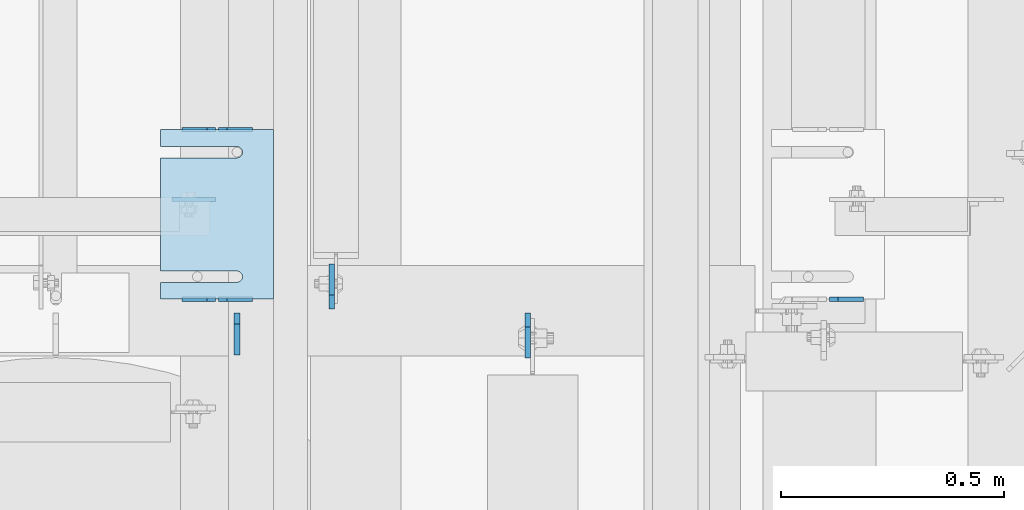
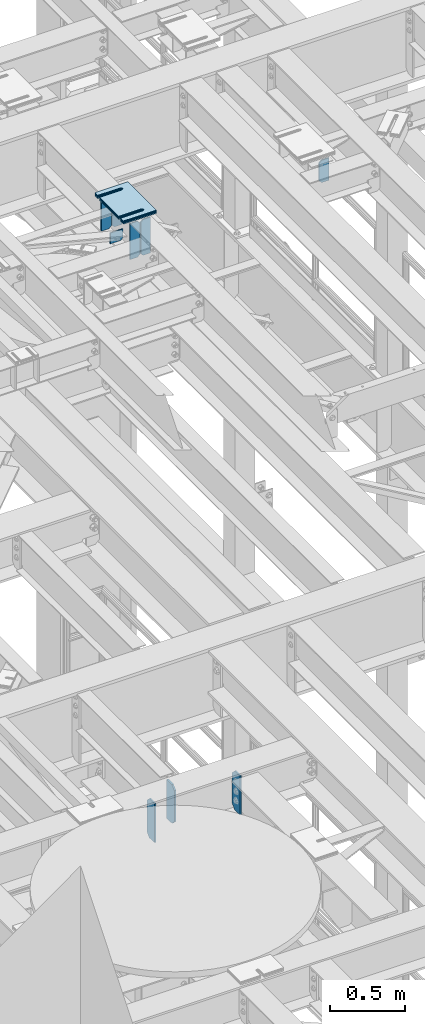
# One storey, part 1716 of 1876: 15 plates, 9 elements without a shape of their own.
"""IFC2X3 building model written with IfcOpenShell, lengths in millimetres."""

from ifc_helpers import new_model, si_unit, frame, origin_with_axes, place, context, subcontext, project, spatial, faceted_brep, material, type_object, element, aggregate, save


model = new_model("IFC2X3")

# Units and contexts
model_context = context("Model", 3, precision=1e-05, world=origin_with_axes())
body_context = subcontext(model_context, "Body", "Model", "MODEL_VIEW")
ifc_project = project(units=[si_unit("LENGTHUNIT", "METRE", prefix="MILLI"), si_unit("AREAUNIT", "SQUARE_METRE"), si_unit("VOLUMEUNIT", "CUBIC_METRE"), si_unit("MASSUNIT", "GRAM", prefix="KILO"), si_unit("TIMEUNIT", "SECOND"), si_unit("PLANEANGLEUNIT", "RADIAN"), si_unit("SOLIDANGLEUNIT", "STERADIAN"), si_unit("THERMODYNAMICTEMPERATUREUNIT", "DEGREE_CELSIUS"), si_unit("LUMINOUSINTENSITYUNIT", "LUMEN")], contexts=[model_context])

# Site, building, storey
site_placement = place(None, origin_with_axes())
site = spatial("IfcSite", under=ifc_project, at=site_placement, CompositionType="ELEMENT")
building_placement = place(site_placement, origin_with_axes())
building = spatial("IfcBuilding", under=site, at=building_placement, Name="Undefined", CompositionType="ELEMENT")
storey_placement = place(building_placement, origin_with_axes())
storey = spatial("IfcBuildingStorey", under=building, at=storey_placement, Name="Undefined", CompositionType="ELEMENT", Elevation=0.0)

# Assembly, plates
assembly_1_placement = place(storey_placement, origin_with_axes())
assembly_1 = element("IfcElementAssembly", 1, at=assembly_1_placement, inside=storey, Name="BEAM", AssemblyPlace="NOTDEFINED", PredefinedType="RIGID_FRAME")
ifc_material = material(Name="STEEL/A36")
plate_type_1 = type_object("IfcPlateType", PredefinedType="NOTDEFINED")
plate_1_placement = place(assembly_1_placement, frame((3813.175, 6273.20591181261, 17681.575), z_axis=(0.0, 0.0, 1.0), x_axis=(-1.0, 0.0, 0.0)))
plate_1 = element("IfcPlate", 2, at=plate_1_placement, type_object=plate_type_1, material=ifc_material, Name="PLATE", context=body_context, shape_type="Brep", body=[
    faceted_brep([(0.0, -4.76249999999982, 0.0), (0.0, -4.76249999999982, 292.100006103516), (0.0, 4.76249999999982, 292.100006103516), (0.0, 4.76249999999982, 0.0), (57.1499977111816, -4.76249999999982, 292.100006103516), (57.1499977111816, 4.76249999999982, 292.100006103516), (76.1999969482422, -4.76249999999982, 273.050006866455), (76.1999969482422, 4.76249999999982, 273.050006866455), (76.1999969482422, -4.76249999999982, 19.0499992370605), (76.1999969482422, 4.76249999999982, 19.0499992370605), (57.1499977111816, -4.76249999999982, 0.0), (57.1499977111816, 4.76249999999982, 0.0)], [[[0, 1, 2, 3]], [[1, 4, 5, 2]], [[4, 6, 7, 5]], [[6, 8, 9, 7]], [[8, 10, 11, 9]], [[10, 0, 3, 11]], [[5, 7, 9, 11, 3, 2]], [[10, 8, 6, 4, 1, 0]]]),
])
plate_2_placement = place(assembly_1_placement, frame((3730.625, 6273.20591181261, 17681.575), z_axis=(0.0, 0.0, 1.0), x_axis=(-1.0, 0.0, 0.0)))
plate_2 = element("IfcPlate", 3, at=plate_2_placement, type_object=plate_type_1, material=ifc_material, Name="PLATE", context=body_context, shape_type="Brep", body=[
    faceted_brep([(0.0, -4.76249999999982, 19.0499992370605), (0.0, -4.76249999999982, 273.050006866455), (0.0, 4.76249999999982, 273.050006866455), (0.0, 4.76249999999982, 19.0499992370605), (19.0499992370605, -4.76249999999982, 292.100006103516), (19.0499992370605, 4.76249999999982, 292.100006103516), (76.1999969482422, -4.76249999999982, 292.100006103516), (76.1999969482422, 4.76249999999982, 292.100006103516), (76.1999969482422, -4.76250000000073, 0.0), (76.1999969482422, 4.76250000000073, 0.0), (19.0499992370605, -4.76249999999982, 0.0), (19.0499992370605, 4.76249999999982, 0.0)], [[[0, 1, 2, 3]], [[1, 4, 5, 2]], [[4, 6, 7, 5]], [[6, 8, 9, 7]], [[8, 10, 11, 9]], [[10, 0, 3, 11]], [[5, 7, 9, 11, 3, 2]], [[10, 8, 6, 4, 1, 0]]]),
])
plate_3_placement = place(assembly_1_placement, frame((3813.175, 6654.20439133079, 17681.575), z_axis=(0.0, 0.0, 1.0), x_axis=(-1.0, 0.0, 0.0)))
plate_3 = element("IfcPlate", 4, at=plate_3_placement, type_object=plate_type_1, material=ifc_material, Name="PLATE", context=body_context, shape_type="Brep", body=[
    faceted_brep([(0.0, -4.76249999999982, 0.0), (0.0, -4.76249999999982, 292.100006103516), (0.0, 4.76249999999982, 292.100006103516), (0.0, 4.76249999999982, 0.0), (57.1499977111816, -4.76249999999982, 292.100006103516), (57.1499977111816, 4.76249999999982, 292.100006103516), (76.1999969482422, -4.76249999999982, 273.050006866455), (76.1999969482422, 4.76249999999982, 273.050006866455), (76.1999969482422, -4.76249999999982, 19.0499992370605), (76.1999969482422, 4.76249999999982, 19.0499992370605), (57.1499977111816, -4.76249999999982, 0.0), (57.1499977111816, 4.76249999999982, 0.0)], [[[0, 1, 2, 3]], [[1, 4, 5, 2]], [[4, 6, 7, 5]], [[6, 8, 9, 7]], [[8, 10, 11, 9]], [[10, 0, 3, 11]], [[5, 7, 9, 11, 3, 2]], [[10, 8, 6, 4, 1, 0]]]),
])
plate_4_placement = place(assembly_1_placement, frame((3730.625, 6654.20439133079, 17681.575), z_axis=(0.0, 0.0, 1.0), x_axis=(-1.0, 0.0, 0.0)))
plate_4 = element("IfcPlate", 5, at=plate_4_placement, type_object=plate_type_1, material=ifc_material, Name="PLATE", context=body_context, shape_type="Brep", body=[
    faceted_brep([(0.0, -4.76249999999982, 19.0499992370605), (0.0, -4.76249999999982, 273.050006866455), (0.0, 4.76249999999982, 273.050006866455), (0.0, 4.76249999999982, 19.0499992370605), (19.0499992370605, -4.76249999999982, 292.100006103516), (19.0499992370605, 4.76249999999982, 292.100006103516), (76.1999969482422, -4.76249999999982, 292.100006103516), (76.1999969482422, 4.76249999999982, 292.100006103516), (76.1999969482422, -4.76250000000073, 0.0), (76.1999969482422, 4.76250000000073, 0.0), (19.0499992370605, -4.76249999999982, 0.0), (19.0499992370605, 4.76249999999982, 0.0)], [[[0, 1, 2, 3]], [[1, 4, 5, 2]], [[4, 6, 7, 5]], [[6, 8, 9, 7]], [[8, 10, 11, 9]], [[10, 0, 3, 11]], [[5, 7, 9, 11, 3, 2]], [[10, 8, 6, 4, 1, 0]]]),
])

# Assembly, plate
assembly_2_placement = place(storey_placement, origin_with_axes())
assembly_2 = element("IfcElementAssembly", 6, at=assembly_2_placement, inside=storey, Name="BEAM", AssemblyPlace="NOTDEFINED", PredefinedType="RIGID_FRAME")
plate_5_placement = place(assembly_2_placement, frame((5184.77401450963, 6273.20592206104, 17792.7), z_axis=(0.0, 0.0, 1.0), x_axis=(-1.0, 0.0, 0.0)))
plate_5 = element("IfcPlate", 7, at=plate_5_placement, type_object=plate_type_1, material=ifc_material, Name="PLATE", context=body_context, shape_type="Brep", body=[
    faceted_brep([(0.0, -4.76249999999982, 0.0), (0.0, -4.76249999999982, 180.975006103516), (0.0, 4.76249999999982, 180.975006103516), (0.0, 4.76249999999982, 0.0), (57.1499977111816, -4.76249999999982, 180.975006103516), (57.1499977111816, 4.76249999999982, 180.975006103516), (76.1999969482422, -4.76249999999982, 161.925006866455), (76.1999969482422, 4.76249999999982, 161.925006866455), (76.1999969482422, -4.76249999999982, 19.0499992370605), (76.1999969482422, 4.76249999999982, 19.0499992370605), (57.1499977111816, -4.76249999999982, 0.0), (57.1499977111816, 4.76249999999982, 0.0)], [[[0, 1, 2, 3]], [[1, 4, 5, 2]], [[4, 6, 7, 5]], [[6, 8, 9, 7]], [[8, 10, 11, 9]], [[10, 0, 3, 11]], [[5, 7, 9, 11, 3, 2]], [[10, 8, 6, 4, 1, 0]]]),
])
aggregate(assembly_2, [plate_5])

# Plate
plate_type_2 = type_object("IfcPlateType", PredefinedType="NOTDEFINED")
plate_6_placement = place(assembly_1_placement, frame((3631.96389926889, 6497.0426411711, 17769.357903729), z_axis=(0.999999999993683, 1.03000000308384e-07, -3.55299999864655e-06), x_axis=(-3.55300000028149e-06, 0.0, -0.999999999993688)))
plate_6 = element("IfcPlate", 8, at=plate_6_placement, type_object=plate_type_2, material=ifc_material, Name="PLATE", context=body_context, shape_type="Brep", body=[
    faceted_brep([(0.0, -4.76249999999982, 0.0), (-0.000350512640579836, -4.76249999997253, 98.6609115600527), (-0.000350512636941858, 4.7625000000271, 98.6609115600545), (0.0, 4.76249999999982, 0.0), (68.7325553897244, -4.76249999997344, 98.6613894576049), (68.7325553897281, 4.7625000000271, 98.6613894576067), (87.7826223897027, -4.76249999997708, 79.6115226746606), (87.7826223897064, 4.76250000002256, 79.6115226746629), (87.782905578526, -4.76249999999891, -1.50066625792533e-11), (87.7829055785296, 4.76250000000073, -1.36424205265939e-11)], [[[0, 1, 2, 3]], [[1, 4, 5, 2]], [[4, 6, 7, 5]], [[6, 8, 9, 7]], [[8, 0, 3, 9]], [[5, 7, 9, 3, 2]], [[8, 6, 4, 1, 0]]]),
])

aggregate(assembly_1, [plate_1, plate_2, plate_3, plate_4, plate_6])

# Assembly, plates
assembly_3_placement = place(storey_placement, origin_with_axes())
assembly_3 = element("IfcElementAssembly", 9, at=assembly_3_placement, inside=storey, Name="BEAM", AssemblyPlace="NOTDEFINED", PredefinedType="RIGID_FRAME")
plate_type_3 = type_object("IfcPlateType", PredefinedType="NOTDEFINED")
plate_7_placement = place(assembly_3_placement, frame((3778.25000000029, 6147.59375, 12976.225), z_axis=(0.0, 0.0, 1.0), x_axis=(0.0, 1.0, 0.0)))
plate_7 = element("IfcPlate", 10, at=plate_7_placement, type_object=plate_type_3, material=ifc_material, Name="PLATE", context=body_context, shape_type="Brep", body=[
    faceted_brep([(0.0, -6.35000000000036, 0.0), (1.81898940354586e-12, -6.35000000000127, 317.5), (0.0, 6.35000000000036, 317.5), (0.0, 6.35000000000036, 0.0), (69.8500003814697, -6.34999999999991, 317.5), (69.8500003814697, 6.34999999999991, 317.5), (95.25, -6.34999999999991, 292.10000038147), (95.25, 6.34999999999991, 292.10000038147), (95.25, -6.34999999999991, 25.3999996185303), (95.25, 6.34999999999991, 25.3999996185303), (69.8500003814697, -6.34999999999991, 0.0), (69.8500003814697, 6.34999999999991, 0.0)], [[[0, 1, 2, 3]], [[1, 4, 5, 2]], [[4, 6, 7, 5]], [[6, 8, 9, 7]], [[8, 10, 11, 9]], [[10, 0, 3, 11]], [[5, 7, 9, 11, 3, 2]], [[10, 8, 6, 4, 1, 0]]]),
])
plate_type_4 = type_object("IfcPlateType", PredefinedType="NOTDEFINED")
plate_8_placement = place(assembly_3_placement, frame((4431.50624990464, 6242.84375, 12977.8125), z_axis=(0.0, 0.0, 1.0), x_axis=(0.0, -1.0, 0.0)))
plate_8 = element("IfcPlate", 11, at=plate_8_placement, type_object=plate_type_4, material=ifc_material, Name="PLATE", context=body_context, shape_type="Brep", body=[
    faceted_brep([(0.0, -6.34999999999991, 31.75), (-1.81898940354586e-12, -6.34999999999991, 284.162506103516), (1.81898940354586e-12, 6.35000000000173, 284.162506103516), (0.0, 6.34999999999991, 31.75), (31.7499999999927, -6.34999999999991, 315.912506103516), (31.7499999999982, 6.35000000000309, 315.912506103516), (101.599998474121, -6.35000000000036, 315.912506103516), (101.599998474121, 6.35000000000036, 315.912506103516), (101.599998474121, -6.35000000000036, 0.0), (101.599998474121, 6.35000000000036, 0.0), (31.75, -6.34999999999991, 0.0), (31.75, 6.34999999999991, 0.0)], [[[0, 1, 2, 3]], [[1, 4, 5, 2]], [[4, 6, 7, 5]], [[6, 8, 9, 7]], [[8, 10, 11, 9]], [[10, 0, 3, 11]], [[5, 7, 9, 11, 3, 2]], [[10, 8, 6, 4, 1, 0]]]),
])
plate_9_placement = place(assembly_3_placement, frame((3990.97499990463, 6250.78125, 12977.8125), z_axis=(0.0, 0.0, 1.0), x_axis=(0.0, 1.0, 0.0)))
plate_9 = element("IfcPlate", 12, at=plate_9_placement, type_object=plate_type_4, material=ifc_material, Name="PLATE", context=body_context, shape_type="Brep", body=[
    faceted_brep([(0.0, -6.34999999999991, 31.75), (-1.81898940354586e-12, -6.34999999999991, 284.162506103516), (1.81898940354586e-12, 6.35000000000173, 284.162506103516), (0.0, 6.34999999999991, 31.75), (31.7499999999927, -6.34999999999991, 315.912506103516), (31.7499999999982, 6.35000000000309, 315.912506103516), (101.599998474121, -6.35000000000036, 315.912506103516), (101.599998474121, 6.35000000000036, 315.912506103516), (101.599998474121, -6.35000000000036, 0.0), (101.599998474121, 6.35000000000036, 0.0), (31.75, -6.34999999999991, 0.0), (31.75, 6.34999999999991, 0.0)], [[[0, 1, 2, 3]], [[1, 4, 5, 2]], [[4, 6, 7, 5]], [[6, 8, 9, 7]], [[8, 10, 11, 9]], [[10, 0, 3, 11]], [[5, 7, 9, 11, 3, 2]], [[10, 8, 6, 4, 1, 0]]]),
])
aggregate(assembly_3, [plate_7, plate_8, plate_9])

# Assembly, plate
assembly_4_placement = place(storey_placement, origin_with_axes())
assembly_4 = element("IfcElementAssembly", 13, at=assembly_4_placement, inside=storey, Name="SHIM PLATE", AssemblyPlace="NOTDEFINED", PredefinedType="RIGID_FRAME")
plate_type_5 = type_object("IfcPlateType", PredefinedType="NOTDEFINED")
plate_10_placement = place(assembly_4_placement, frame((3860.80063238647, 6654.20335755462, 18007.0115), z_axis=(-1.0, 0.0, 0.0), x_axis=(0.0, -1.0, 0.0)))
plate_10 = element("IfcPlate", 14, at=plate_10_placement, type_object=plate_type_5, material=ifc_material, Name="SHIM PLATE", context=body_context, shape_type="Brep", body=[
    faceted_brep([(38.1710562683074, -1.58750000000146, 253.999557495119), (38.1732778844053, -1.58750000000146, 82.6182316462764), (38.1732778844053, 1.58750000000146, 82.6182316462764), (38.1710562683074, 1.58750000000146, 253.999557495119), (39.8747477728821, -1.58750000000146, 76.2682283464169), (39.8747477728821, 1.58750000000146, 76.2682283464169), (44.523266268131, -1.58750000000146, 71.6196998169826), (44.523266268131, 1.58750000000146, 71.6196998169826), (50.8732658952267, -1.58750000000146, 69.9182162215529), (50.8732658952267, 1.58750000000146, 69.9182162215529), (57.2232684284982, -1.58750000000146, 71.6196889709886), (57.2232684284982, 1.58750000000146, 71.6196889709886), (61.8717948635667, -1.58750000000146, 76.2682095606051), (61.8717948635667, 1.58750000000146, 76.2682095606051), (63.5732755980398, -1.58750000000146, 82.6182099542939), (63.5732755980398, 1.58750000000146, 82.6182099542939), (63.5710539816291, -1.58750000000146, 253.999557596195), (63.5710539816291, 1.58750000000146, 253.99955749512), (9.09494701772928e-13, -1.58750000000146, 4.54747350886464e-13), (1.89071320164658e-05, -1.58750000000146, 253.999557495117), (1.89071320164658e-05, 1.58750000000146, 253.999557495117), (9.09494701772928e-13, 1.58750000000146, 4.54747350886464e-13), (380.998474121094, -1.58750000000146, -2.41016095969826e-11), (380.998474121094, 1.58750000000146, -2.41016095969826e-11), (380.998504638661, -1.58750000000146, 253.999557495133), (380.998504638661, 1.58750000000146, 253.999557495133), (342.971054337228, 1.58750000000146, 253.999557495132), (342.971054337228, -1.58750000000146, 253.999557596208), (342.973275782132, 1.58750000000146, 82.6182252130961), (342.973275782132, -1.58750000000146, 82.6182252130961), (341.271801399192, 1.58750000000146, 76.2682205744086), (341.271801399192, -1.58750000000146, 76.2682205744086), (336.623277411347, 1.58750000000146, 71.6196940636119), (336.623277411347, -1.58750000000146, 71.6196940636119), (330.273273696123, 1.58750000000146, 69.9182162342554), (330.273273696123, -1.58750000000146, 69.9182162342554), (323.923270846187, 1.58750000000146, 71.6196972929051), (323.923270846187, -1.58750000000146, 71.6196972929051), (319.274749222349, 1.58750000000146, 76.2682261677069), (319.274749222349, -1.58750000000146, 76.2682261677069), (317.573278068704, 1.58750000000146, 82.6182316716777), (317.573278068704, -1.58750000000146, 82.6182316716777), (317.571056623908, -1.58750000000146, 253.99955749513), (317.571056623908, 1.58750000000146, 253.99955749513)], [[[0, 1, 2, 3]], [[4, 5, 2, 1]], [[6, 7, 5, 4]], [[8, 9, 7, 6]], [[10, 11, 9, 8]], [[12, 13, 11, 10]], [[14, 15, 13, 12]], [[16, 17, 15, 14]], [[18, 19, 20, 21]], [[22, 18, 21, 23]], [[24, 22, 23, 25]], [[24, 25, 26, 27]], [[27, 26, 28, 29]], [[29, 28, 30, 31]], [[31, 30, 32, 33]], [[33, 32, 34, 35]], [[35, 34, 36, 37]], [[37, 36, 38, 39]], [[39, 38, 40, 41]], [[42, 41, 40, 43]], [[12, 10, 8, 6, 4, 1, 0, 19, 18, 22, 24, 27, 29, 31, 33, 35, 37, 39, 41, 42, 16, 14]], [[20, 19, 0, 3]], [[43, 40, 38, 36, 34, 32, 30, 28, 26, 25, 23, 21, 20, 3, 2, 5, 7, 9, 11, 13, 15, 17]], [[42, 43, 17, 16]]]),
])
aggregate(assembly_4, [plate_10])

assembly_5_placement = place(storey_placement, origin_with_axes())
assembly_5 = element("IfcElementAssembly", 15, at=assembly_5_placement, inside=storey, Name="SHIM PLATE", AssemblyPlace="NOTDEFINED", PredefinedType="RIGID_FRAME")
plate_11_placement = place(assembly_5_placement, frame((3860.80063238647, 6654.20335755462, 18003.8365), z_axis=(-1.0, 0.0, 0.0), x_axis=(0.0, -1.0, 0.0)))
plate_11 = element("IfcPlate", 16, at=plate_11_placement, type_object=plate_type_5, material=ifc_material, Name="SHIM PLATE", context=body_context, shape_type="Brep", body=[
    faceted_brep([(38.1710562683074, -1.58750000000146, 253.999557495119), (38.1732778844053, -1.58750000000146, 82.6182316462764), (38.1732778844053, 1.58750000000146, 82.6182316462764), (38.1710562683074, 1.58750000000146, 253.999557495119), (39.8747477728821, -1.58750000000146, 76.2682283464169), (39.8747477728821, 1.58750000000146, 76.2682283464169), (44.523266268131, -1.58750000000146, 71.6196998169826), (44.523266268131, 1.58750000000146, 71.6196998169826), (50.8732658952267, -1.58750000000146, 69.9182162215529), (50.8732658952267, 1.58750000000146, 69.9182162215529), (57.2232684284982, -1.58750000000146, 71.6196889709886), (57.2232684284982, 1.58750000000146, 71.6196889709886), (61.8717948635667, -1.58750000000146, 76.2682095606051), (61.8717948635667, 1.58750000000146, 76.2682095606051), (63.5732755980398, -1.58750000000146, 82.6182099542939), (63.5732755980398, 1.58750000000146, 82.6182099542939), (63.5710539816291, -1.58750000000146, 253.999557596195), (63.5710539816291, 1.58750000000146, 253.99955749512), (9.09494701772928e-13, -1.58750000000146, 4.54747350886464e-13), (1.89071320164658e-05, -1.58750000000146, 253.999557495117), (1.89071320164658e-05, 1.58750000000146, 253.999557495117), (9.09494701772928e-13, 1.58750000000146, 4.54747350886464e-13), (380.998474121094, -1.58750000000146, -2.41016095969826e-11), (380.998474121094, 1.58750000000146, -2.41016095969826e-11), (380.998504638661, -1.58750000000146, 253.999557495133), (380.998504638661, 1.58750000000146, 253.999557495133), (342.971054337228, 1.58750000000146, 253.999557495132), (342.971054337228, -1.58750000000146, 253.999557596208), (342.973275782132, 1.58750000000146, 82.6182252130961), (342.973275782132, -1.58750000000146, 82.6182252130961), (341.271801399192, 1.58750000000146, 76.2682205744086), (341.271801399192, -1.58750000000146, 76.2682205744086), (336.623277411347, 1.58750000000146, 71.6196940636119), (336.623277411347, -1.58750000000146, 71.6196940636119), (330.273273696123, 1.58750000000146, 69.9182162342554), (330.273273696123, -1.58750000000146, 69.9182162342554), (323.923270846187, 1.58750000000146, 71.6196972929051), (323.923270846187, -1.58750000000146, 71.6196972929051), (319.274749222349, 1.58750000000146, 76.2682261677069), (319.274749222349, -1.58750000000146, 76.2682261677069), (317.573278068704, 1.58750000000146, 82.6182316716777), (317.573278068704, -1.58750000000146, 82.6182316716777), (317.571056623908, -1.58750000000146, 253.99955749513), (317.571056623908, 1.58750000000146, 253.99955749513)], [[[0, 1, 2, 3]], [[4, 5, 2, 1]], [[6, 7, 5, 4]], [[8, 9, 7, 6]], [[10, 11, 9, 8]], [[12, 13, 11, 10]], [[14, 15, 13, 12]], [[16, 17, 15, 14]], [[18, 19, 20, 21]], [[22, 18, 21, 23]], [[24, 22, 23, 25]], [[24, 25, 26, 27]], [[27, 26, 28, 29]], [[29, 28, 30, 31]], [[31, 30, 32, 33]], [[33, 32, 34, 35]], [[35, 34, 36, 37]], [[37, 36, 38, 39]], [[39, 38, 40, 41]], [[42, 41, 40, 43]], [[12, 10, 8, 6, 4, 1, 0, 19, 18, 22, 24, 27, 29, 31, 33, 35, 37, 39, 41, 42, 16, 14]], [[20, 19, 0, 3]], [[43, 40, 38, 36, 34, 32, 30, 28, 26, 25, 23, 21, 20, 3, 2, 5, 7, 9, 11, 13, 15, 17]], [[42, 43, 17, 16]]]),
])
aggregate(assembly_5, [plate_11])

assembly_6_placement = place(storey_placement, origin_with_axes())
assembly_6 = element("IfcElementAssembly", 17, at=assembly_6_placement, inside=storey, Name="SHIM PLATE", AssemblyPlace="NOTDEFINED", PredefinedType="RIGID_FRAME")
plate_type_6 = type_object("IfcPlateType", PredefinedType="NOTDEFINED")
plate_12_placement = place(assembly_6_placement, frame((3860.80063238647, 6654.20335755462, 18009.3925), z_axis=(-1.0, 0.0, 0.0), x_axis=(0.0, -1.0, 0.0)))
plate_12 = element("IfcPlate", 18, at=plate_12_placement, type_object=plate_type_6, material=ifc_material, Name="SHIM PLATE", context=body_context, shape_type="Brep", body=[
    faceted_brep([(38.1710562683074, -0.793499999999767, 253.999557495119), (38.1732778844053, -0.793499999999767, 82.6182316462764), (38.1732778844053, 0.793499999999767, 82.6182316462764), (38.1710562683074, 0.793499999999767, 253.999557495119), (39.8747477728821, -0.793499999999767, 76.2682283464169), (39.8747477728821, 0.793499999999767, 76.2682283464169), (44.523266268131, -0.793499999999767, 71.6196998169826), (44.523266268131, 0.793499999999767, 71.6196998169826), (50.8732658952267, -0.793499999999767, 69.9182162215529), (50.8732658952267, 0.793499999999767, 69.9182162215529), (57.2232684284982, -0.793499999999767, 71.6196889709886), (57.2232684284982, 0.793499999999767, 71.6196889709886), (61.8717948635667, -0.793499999999767, 76.2682095606051), (61.8717948635667, 0.793499999999767, 76.2682095606051), (63.5732755980398, -0.793499999999767, 82.6182099542939), (63.5732755980398, 0.793499999999767, 82.6182099542939), (63.5710539816291, -0.793499999999767, 253.999557596195), (63.5710539816291, 0.793499999999767, 253.99955749512), (9.09494701772928e-13, -0.793499999999767, 0.0), (1.89070156011439e-05, -0.793499999999767, 253.999557495117), (1.89070156011439e-05, 0.793499999999767, 253.999557495117), (9.09494701772928e-13, 0.793499999999767, 0.0), (380.998474121094, -0.793499999999767, -2.41016095969826e-11), (380.998474121094, 0.793499999999767, -2.41016095969826e-11), (380.998504638661, -0.793499999999767, 253.999557495133), (380.998504638661, 0.793499999999767, 253.999557495133), (342.971054337228, 0.793499999999767, 253.999557495132), (342.971054337228, -0.793499999999767, 253.999557596208), (342.973275782132, 0.793499999999767, 82.6182252130961), (342.973275782132, -0.793499999999767, 82.6182252130961), (341.271801399192, 0.793499999999767, 76.2682205744086), (341.271801399192, -0.793499999999767, 76.2682205744086), (336.623277411347, 0.793499999999767, 71.6196940636119), (336.623277411347, -0.793499999999767, 71.6196940636119), (330.273273696123, 0.793499999999767, 69.9182162342554), (330.273273696123, -0.793499999999767, 69.9182162342554), (323.923270846187, 0.793499999999767, 71.6196972929051), (323.923270846187, -0.793499999999767, 71.6196972929051), (319.274749222349, 0.793499999999767, 76.2682261677069), (319.274749222349, -0.793499999999767, 76.2682261677069), (317.573278068704, 0.793499999999767, 82.6182316716777), (317.573278068704, -0.793499999999767, 82.6182316716777), (317.571056623908, -0.793499999999767, 253.99955749513), (317.571056623908, 0.793499999999767, 253.99955749513)], [[[0, 1, 2, 3]], [[4, 5, 2, 1]], [[6, 7, 5, 4]], [[8, 9, 7, 6]], [[10, 11, 9, 8]], [[12, 13, 11, 10]], [[14, 15, 13, 12]], [[16, 17, 15, 14]], [[18, 19, 20, 21]], [[22, 18, 21, 23]], [[24, 22, 23, 25]], [[24, 25, 26, 27]], [[27, 26, 28, 29]], [[29, 28, 30, 31]], [[31, 30, 32, 33]], [[33, 32, 34, 35]], [[35, 34, 36, 37]], [[37, 36, 38, 39]], [[39, 38, 40, 41]], [[42, 41, 40, 43]], [[12, 10, 8, 6, 4, 1, 0, 19, 18, 22, 24, 27, 29, 31, 33, 35, 37, 39, 41, 42, 16, 14]], [[20, 19, 0, 3]], [[43, 40, 38, 36, 34, 32, 30, 28, 26, 25, 23, 21, 20, 3, 2, 5, 7, 9, 11, 13, 15, 17]], [[42, 43, 17, 16]]]),
])
aggregate(assembly_6, [plate_12])

assembly_7_placement = place(storey_placement, origin_with_axes())
assembly_7 = element("IfcElementAssembly", 19, at=assembly_7_placement, inside=storey, Name="SHIM PLATE", AssemblyPlace="NOTDEFINED", PredefinedType="RIGID_FRAME")
plate_type_7 = type_object("IfcPlateType", PredefinedType="NOTDEFINED")
plate_13_placement = place(assembly_7_placement, frame((3860.80063238647, 6654.20335755462, 17999.868), z_axis=(-1.0, 0.0, 0.0), x_axis=(0.0, -1.0, 0.0)))
plate_13 = element("IfcPlate", 20, at=plate_13_placement, type_object=plate_type_7, material=ifc_material, Name="SHIM PLATE", context=body_context, shape_type="Brep", body=[
    faceted_brep([(38.1710562683056, -2.38100000000122, 253.999557495119), (38.1732778844034, -2.38100000000122, 82.6182316462764), (38.1732778844034, 2.38100000000122, 82.6182316462764), (38.1710562683056, 2.38100000000122, 253.999557495119), (39.8747477728803, -2.38100000000122, 76.2682283464169), (39.8747477728803, 2.38100000000122, 76.2682283464169), (44.5232662681292, -2.38100000000122, 71.6196998169826), (44.5232662681292, 2.38100000000122, 71.6196998169826), (50.8732658952249, -2.38100000000122, 69.9182162215529), (50.8732658952249, 2.38100000000122, 69.9182162215529), (57.2232684284963, -2.38100000000122, 71.6196889709886), (57.2232684284963, 2.38100000000122, 71.6196889709886), (61.8717948635649, -2.38100000000122, 76.2682095606051), (61.8717948635649, 2.38100000000122, 76.2682095606051), (63.573275598038, -2.38100000000122, 82.6182099542939), (63.573275598038, 2.38100000000122, 82.6182099542939), (63.5710539816273, -2.38100000000122, 253.999557596195), (63.5710539816273, 2.38100000000122, 253.99955749512), (0.0, -2.38100000000122, 4.54747350886464e-13), (1.89072484317876e-05, -2.38100000000122, 253.999557495117), (1.89072484317876e-05, 2.38100000000122, 253.999557495117), (0.0, 2.38100000000122, 4.54747350886464e-13), (380.998474121094, -2.38100000000122, -2.41016095969826e-11), (380.998474121094, 2.38100000000122, -2.41016095969826e-11), (380.998504638661, -2.38100000000122, 253.999557495133), (380.998504638661, 2.38100000000122, 253.999557495133), (342.971054337227, 2.38100000000122, 253.999557495132), (342.971054337227, -2.38100000000122, 253.999557596208), (342.97327578213, 2.38100000000122, 82.6182252130961), (342.97327578213, -2.38100000000122, 82.6182252130961), (341.27180139919, 2.38100000000122, 76.2682205744086), (341.27180139919, -2.38100000000122, 76.2682205744086), (336.623277411345, 2.38100000000122, 71.6196940636119), (336.623277411345, -2.38100000000122, 71.6196940636119), (330.273273696122, 2.38100000000122, 69.9182162342554), (330.273273696122, -2.38100000000122, 69.9182162342554), (323.923270846185, 2.38100000000122, 71.6196972929051), (323.923270846185, -2.38100000000122, 71.6196972929051), (319.274749222347, 2.38100000000122, 76.2682261677069), (319.274749222347, -2.38100000000122, 76.2682261677069), (317.573278068702, 2.38100000000122, 82.6182316716777), (317.573278068702, -2.38100000000122, 82.6182316716777), (317.571056623906, -2.38100000000122, 253.99955749513), (317.571056623906, 2.38100000000122, 253.99955749513)], [[[0, 1, 2, 3]], [[4, 5, 2, 1]], [[6, 7, 5, 4]], [[8, 9, 7, 6]], [[10, 11, 9, 8]], [[12, 13, 11, 10]], [[14, 15, 13, 12]], [[16, 17, 15, 14]], [[18, 19, 20, 21]], [[22, 18, 21, 23]], [[24, 22, 23, 25]], [[24, 25, 26, 27]], [[27, 26, 28, 29]], [[29, 28, 30, 31]], [[31, 30, 32, 33]], [[33, 32, 34, 35]], [[35, 34, 36, 37]], [[37, 36, 38, 39]], [[39, 38, 40, 41]], [[42, 41, 40, 43]], [[12, 10, 8, 6, 4, 1, 0, 19, 18, 22, 24, 27, 29, 31, 33, 35, 37, 39, 41, 42, 16, 14]], [[20, 19, 0, 3]], [[43, 40, 38, 36, 34, 32, 30, 28, 26, 25, 23, 21, 20, 3, 2, 5, 7, 9, 11, 13, 15, 17]], [[42, 43, 17, 16]]]),
])
aggregate(assembly_7, [plate_13])

assembly_8_placement = place(storey_placement, origin_with_axes())
assembly_8 = element("IfcElementAssembly", 21, at=assembly_8_placement, inside=storey, Name="SHIM PLATE", AssemblyPlace="NOTDEFINED", PredefinedType="RIGID_FRAME")
plate_14_placement = place(assembly_8_placement, frame((3860.80063238646, 6654.20335755462, 17995.106), z_axis=(-1.0, 0.0, 0.0), x_axis=(0.0, -1.0, 0.0)))
plate_14 = element("IfcPlate", 22, at=plate_14_placement, type_object=plate_type_7, material=ifc_material, Name="SHIM PLATE", context=body_context, shape_type="Brep", body=[
    faceted_brep([(38.1710562683056, -2.38100000000122, 253.999557495119), (38.1732778844034, -2.38100000000122, 82.6182316462764), (38.1732778844034, 2.38100000000122, 82.6182316462764), (38.1710562683056, 2.38100000000122, 253.999557495119), (39.8747477728803, -2.38100000000122, 76.2682283464169), (39.8747477728803, 2.38100000000122, 76.2682283464169), (44.5232662681292, -2.38100000000122, 71.6196998169826), (44.5232662681292, 2.38100000000122, 71.6196998169826), (50.8732658952249, -2.38100000000122, 69.9182162215529), (50.8732658952249, 2.38100000000122, 69.9182162215529), (57.2232684284963, -2.38100000000122, 71.6196889709886), (57.2232684284963, 2.38100000000122, 71.6196889709886), (61.8717948635649, -2.38100000000122, 76.2682095606051), (61.8717948635649, 2.38100000000122, 76.2682095606051), (63.573275598038, -2.38100000000122, 82.6182099542939), (63.573275598038, 2.38100000000122, 82.6182099542939), (63.5710539816273, -2.38100000000122, 253.999557596195), (63.5710539816273, 2.38100000000122, 253.99955749512), (0.0, -2.38100000000122, 4.54747350886464e-13), (1.89072484317876e-05, -2.38100000000122, 253.999557495117), (1.89072484317876e-05, 2.38100000000122, 253.999557495117), (0.0, 2.38100000000122, 4.54747350886464e-13), (380.998474121094, -2.38100000000122, -2.41016095969826e-11), (380.998474121094, 2.38100000000122, -2.41016095969826e-11), (380.998504638661, -2.38100000000122, 253.999557495133), (380.998504638661, 2.38100000000122, 253.999557495133), (342.971054337227, 2.38100000000122, 253.999557495132), (342.971054337227, -2.38100000000122, 253.999557596208), (342.97327578213, 2.38100000000122, 82.6182252130961), (342.97327578213, -2.38100000000122, 82.6182252130961), (341.27180139919, 2.38100000000122, 76.2682205744086), (341.27180139919, -2.38100000000122, 76.2682205744086), (336.623277411345, 2.38100000000122, 71.6196940636119), (336.623277411345, -2.38100000000122, 71.6196940636119), (330.273273696122, 2.38100000000122, 69.9182162342554), (330.273273696122, -2.38100000000122, 69.9182162342554), (323.923270846185, 2.38100000000122, 71.6196972929051), (323.923270846185, -2.38100000000122, 71.6196972929051), (319.274749222347, 2.38100000000122, 76.2682261677069), (319.274749222347, -2.38100000000122, 76.2682261677069), (317.573278068702, 2.38100000000122, 82.6182316716777), (317.573278068702, -2.38100000000122, 82.6182316716777), (317.571056623906, -2.38100000000122, 253.99955749513), (317.571056623906, 2.38100000000122, 253.99955749513)], [[[0, 1, 2, 3]], [[4, 5, 2, 1]], [[6, 7, 5, 4]], [[8, 9, 7, 6]], [[10, 11, 9, 8]], [[12, 13, 11, 10]], [[14, 15, 13, 12]], [[16, 17, 15, 14]], [[18, 19, 20, 21]], [[22, 18, 21, 23]], [[24, 22, 23, 25]], [[24, 25, 26, 27]], [[27, 26, 28, 29]], [[29, 28, 30, 31]], [[31, 30, 32, 33]], [[33, 32, 34, 35]], [[35, 34, 36, 37]], [[37, 36, 38, 39]], [[39, 38, 40, 41]], [[42, 41, 40, 43]], [[12, 10, 8, 6, 4, 1, 0, 19, 18, 22, 24, 27, 29, 31, 33, 35, 37, 39, 41, 42, 16, 14]], [[20, 19, 0, 3]], [[43, 40, 38, 36, 34, 32, 30, 28, 26, 25, 23, 21, 20, 3, 2, 5, 7, 9, 11, 13, 15, 17]], [[42, 43, 17, 16]]]),
])
aggregate(assembly_8, [plate_14])

assembly_9_placement = place(storey_placement, origin_with_axes())
assembly_9 = element("IfcElementAssembly", 23, at=assembly_9_placement, inside=storey, Name="SHIM PLATE", AssemblyPlace="NOTDEFINED", PredefinedType="RIGID_FRAME")
plate_type_8 = type_object("IfcPlateType", PredefinedType="NOTDEFINED")
plate_15_placement = place(assembly_9_placement, frame((3860.80063238646, 6654.20335755462, 17987.9625), z_axis=(-1.0, 0.0, 0.0), x_axis=(0.0, -1.0, 0.0)))
plate_15 = element("IfcPlate", 24, at=plate_15_placement, type_object=plate_type_8, material=ifc_material, Name="SHIM PLATE", context=body_context, shape_type="Brep", body=[
    faceted_brep([(38.1710562683074, -4.76250000000073, 253.999557495119), (38.1732778844053, -4.76250000000073, 82.6182316462764), (38.1732778844053, 4.76250000000073, 82.6182316462764), (38.1710562683074, 4.76250000000073, 253.999557495119), (39.8747477728821, -4.76250000000073, 76.2682283464169), (39.8747477728821, 4.76250000000073, 76.2682283464169), (44.523266268131, -4.76250000000073, 71.6196998169826), (44.523266268131, 4.76250000000073, 71.6196998169826), (50.8732658952267, -4.76250000000073, 69.9182162215529), (50.8732658952267, 4.76250000000073, 69.9182162215529), (57.2232684284982, -4.76250000000073, 71.6196889709886), (57.2232684284982, 4.76250000000073, 71.6196889709886), (61.8717948635667, -4.76250000000073, 76.2682095606051), (61.8717948635667, 4.76250000000073, 76.2682095606051), (63.5732755980398, -4.76250000000073, 82.6182099542939), (63.5732755980398, 4.76250000000073, 82.6182099542939), (63.5710539816291, -4.76250000000073, 253.999557596195), (63.5710539816291, 4.76250000000073, 253.99955749512), (0.0, -4.76249999999982, 0.0), (1.89073648471094e-05, -4.76250000000073, 253.999557495117), (1.89073648471094e-05, 4.76250000000073, 253.999557495117), (0.0, 4.76249999999982, 0.0), (380.998474121094, -4.76250000000073, -2.41016095969826e-11), (380.998474121094, 4.76250000000073, -2.41016095969826e-11), (380.998504638661, -4.76250000000073, 253.999557495133), (380.998504638661, 4.76250000000073, 253.999557495133), (342.971054337228, 4.76250000000073, 253.999557495132), (342.971054337228, -4.76250000000073, 253.999557596208), (342.973275782132, 4.76250000000073, 82.6182252130961), (342.973275782132, -4.76250000000073, 82.6182252130961), (341.271801399192, 4.76250000000073, 76.2682205744086), (341.271801399192, -4.76250000000073, 76.2682205744086), (336.623277411347, 4.76250000000073, 71.6196940636119), (336.623277411347, -4.76250000000073, 71.6196940636119), (330.273273696123, 4.76250000000073, 69.9182162342554), (330.273273696123, -4.76250000000073, 69.9182162342554), (323.923270846187, 4.76250000000073, 71.6196972929051), (323.923270846187, -4.76250000000073, 71.6196972929051), (319.274749222349, 4.76250000000073, 76.2682261677069), (319.274749222349, -4.76250000000073, 76.2682261677069), (317.573278068704, 4.76250000000073, 82.6182316716777), (317.573278068704, -4.76250000000073, 82.6182316716777), (317.571056623908, -4.76250000000073, 253.99955749513), (317.571056623908, 4.76250000000073, 253.99955749513)], [[[0, 1, 2, 3]], [[4, 5, 2, 1]], [[6, 7, 5, 4]], [[8, 9, 7, 6]], [[10, 11, 9, 8]], [[12, 13, 11, 10]], [[14, 15, 13, 12]], [[16, 17, 15, 14]], [[18, 19, 20, 21]], [[22, 18, 21, 23]], [[24, 22, 23, 25]], [[24, 25, 26, 27]], [[27, 26, 28, 29]], [[29, 28, 30, 31]], [[31, 30, 32, 33]], [[33, 32, 34, 35]], [[35, 34, 36, 37]], [[37, 36, 38, 39]], [[39, 38, 40, 41]], [[42, 41, 40, 43]], [[12, 10, 8, 6, 4, 1, 0, 19, 18, 22, 24, 27, 29, 31, 33, 35, 37, 39, 41, 42, 16, 14]], [[20, 19, 0, 3]], [[43, 40, 38, 36, 34, 32, 30, 28, 26, 25, 23, 21, 20, 3, 2, 5, 7, 9, 11, 13, 15, 17]], [[42, 43, 17, 16]]]),
])
aggregate(assembly_9, [plate_15])

save(model, "model.ifc")
